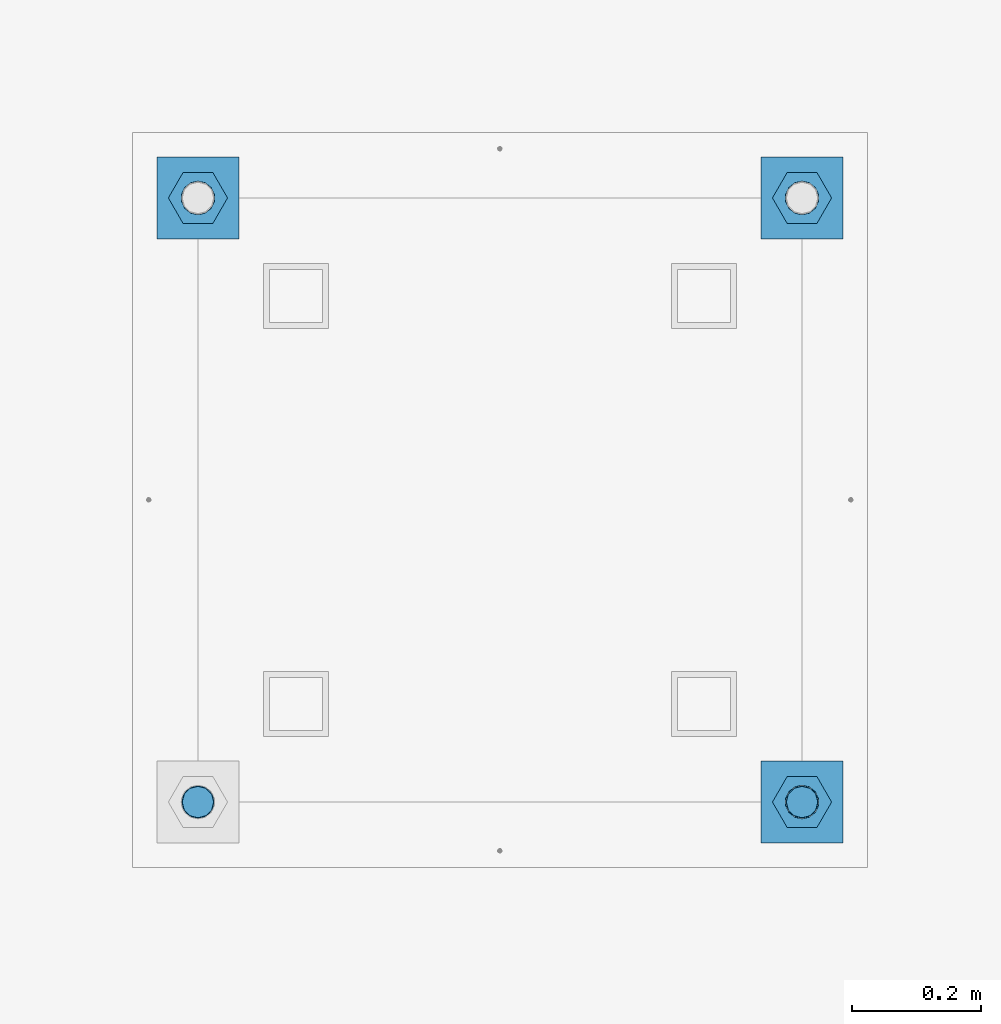
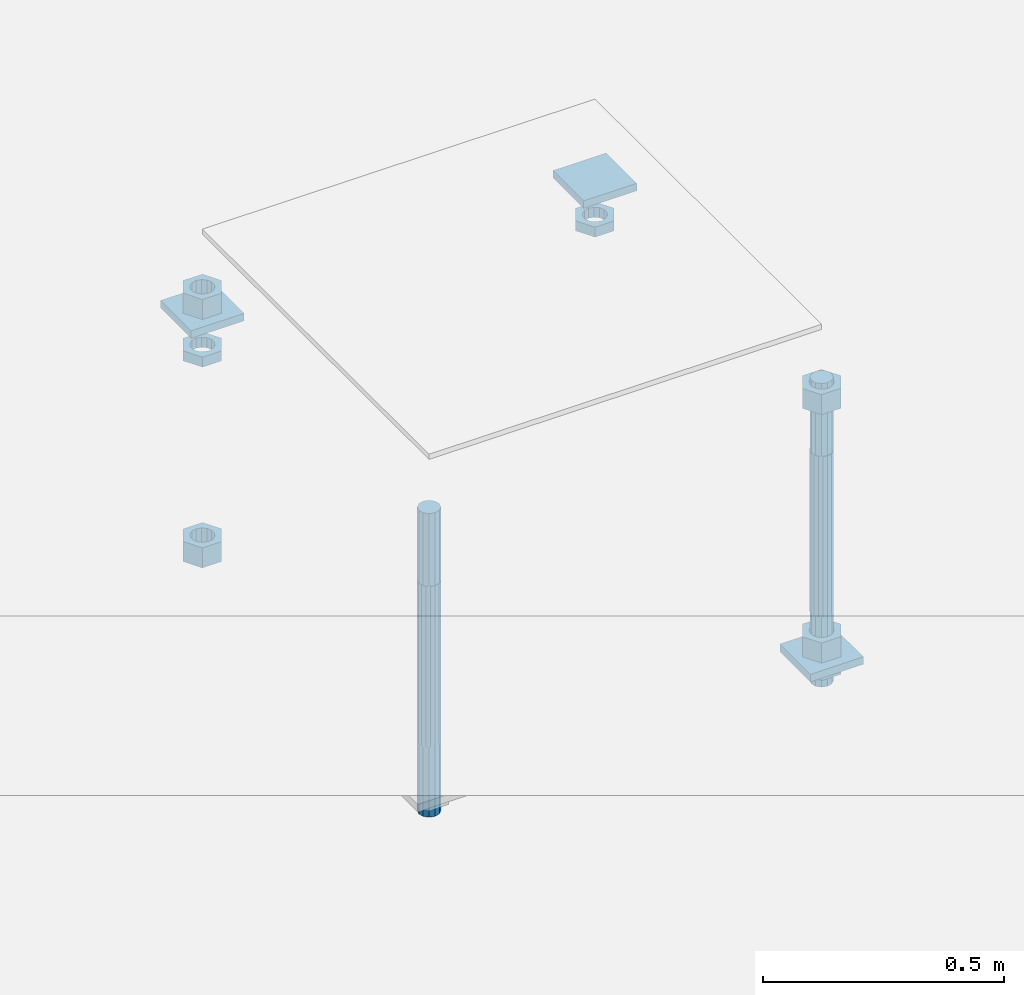
# One storey, part 2697 of 3843: 12 beams, 1 element without a shape of its own.
"""IFC2X3 building model written with IfcOpenShell, lengths in millimetres."""

import ifcopenshell
import ifcopenshell.guid

model = None  # the IFC model being written
_history = None  # IfcOwnerHistory: only IFC2X3 demands one
_inside = {}  # id of a spatial element -> (the spatial element, [elements in it])
_under = {}  # id of a project, library or spatial element -> (it, [spatial elements below it])
_declared = {}  # id of a project -> (the project, [libraries it declares])
_typed = {}  # id of a type object -> (the type object, [elements of that type])
_made_of = {}  # id of a material, layer set ... -> (it, [elements and type objects made of it])


def new_model(schema):
    """Start an empty IFC model of exactly this schema.

    Asked for "IFC4X3", IfcOpenShell would pick the latest addendum, in which some entities
    have other attributes; the version numbers below select the first issue.
    IFC2X3 requires an IfcOwnerHistory on every rooted entity: one is made here for all.
    """
    global model, _history
    if schema == "IFC4X3":
        model = ifcopenshell.file(schema_version=(4, 3, 0, 0))
    else:
        model = ifcopenshell.file(schema=schema)
    _inside.clear()
    _under.clear()
    _declared.clear()
    _typed.clear()
    _made_of.clear()
    _history = None
    if model.schema == "IFC2X3":
        org = make("IfcOrganization", Name="unknown")
        user = make(
            "IfcPersonAndOrganization",
            ThePerson=make("IfcPerson", FamilyName="unknown"),
            TheOrganization=org,
        )
        app = make(
            "IfcApplication",
            ApplicationDeveloper=org,
            Version="unknown",
            ApplicationFullName="unknown",
            ApplicationIdentifier="unknown",
        )
        _history = make(
            "IfcOwnerHistory",
            OwningUser=user,
            OwningApplication=app,
            ChangeAction="ADDED",
            CreationDate=0,
        )
    return model


def make(cls, **values):
    """One entity of the class cls with the attributes given. An attribute that is None is left unset."""
    return model.create_entity(
        cls, **{name: value for name, value in values.items() if value is not None}
    )


def rooted(cls, **values):
    """An entity with a GlobalId (a new one), such as an element, a storey or a relation."""
    return make(cls, GlobalId=ifcopenshell.guid.new(), OwnerHistory=_history, **values)


def si_unit(unit_type, name, prefix=None):
    """IfcSIUnit, for example si_unit("LENGTHUNIT", "METRE", prefix="MILLI")."""
    return make("IfcSIUnit", UnitType=unit_type, Prefix=prefix, Name=name)


def assignment(units):
    """IfcUnitAssignment: the units of a project."""
    return None if units is None else make("IfcUnitAssignment", Units=units)


def point(xyz):
    """IfcCartesianPoint."""
    return None if xyz is None else make("IfcCartesianPoint", Coordinates=xyz)


def direction(xyz):
    """IfcDirection."""
    return None if xyz is None else make("IfcDirection", DirectionRatios=xyz)


def frame(location, z_axis=None, x_axis=None):
    """IfcAxis2Placement3D, a coordinate frame: its origin and axes. An axis left out is left unset."""
    return make(
        "IfcAxis2Placement3D",
        Location=point(location),
        Axis=direction(z_axis),
        RefDirection=direction(x_axis),
    )


def origin_with_axes():
    """The frame at (0, 0, 0) with the z axis (0, 0, 1) and the x axis (1, 0, 0) written out."""
    return frame((0.0, 0.0, 0.0), z_axis=(0.0, 0.0, 1.0), x_axis=(1.0, 0.0, 0.0))


def place(relative_to, where):
    """IfcLocalPlacement: puts the frame where relative to a parent placement (None: the world)."""
    return make(
        "IfcLocalPlacement", PlacementRelTo=relative_to, RelativePlacement=where
    )


def context(
    kind, dimensions, precision=None, world=None, true_north=None, identifier=None
):
    """IfcGeometricRepresentationContext, for example the 3D "Model" context."""
    return make(
        "IfcGeometricRepresentationContext",
        ContextIdentifier=identifier,
        ContextType=kind,
        CoordinateSpaceDimension=dimensions,
        Precision=precision,
        WorldCoordinateSystem=world,
        TrueNorth=true_north,
    )


def subcontext(parent, identifier, kind, view, scale=None):
    """IfcGeometricRepresentationSubContext, for example "Body" below "Model"."""
    return make(
        "IfcGeometricRepresentationSubContext",
        ContextIdentifier=identifier,
        ContextType=kind,
        ParentContext=parent,
        TargetScale=scale,
        TargetView=view,
    )


def project(units=None, contexts=None):
    """IfcProject with its units and contexts."""
    return rooted(
        "IfcProject",
        Name="project",
        RepresentationContexts=contexts,
        UnitsInContext=assignment(units),
    )


def spatial(cls, under=None, at=None, **own):
    """A site, building, storey or space (cls), placed at a placement, below another one or the project."""
    s = rooted(cls, ObjectPlacement=at, **own)
    if under is not None:
        _under.setdefault(under.id(), (under, []))[1].append(s)
    return s


def faces_of(points, faces, orient=None, outer=None):
    """IfcFace entities. A face is a list of loops; a loop is a list of indices into points, from 0.

    orient and outer hold one flag for each loop. By default every Orientation is true, the
    first loop of a face is its IfcFaceOuterBound and the others are IfcFaceBound.
    """
    made = []
    for i, loops in enumerate(faces):
        bounds = []
        for j, loop in enumerate(loops):
            is_outer = j == 0 if outer is None else outer[i][j]
            bounds.append(
                make(
                    "IfcFaceOuterBound" if is_outer else "IfcFaceBound",
                    Bound=make("IfcPolyLoop", Polygon=[points[k] for k in loop]),
                    Orientation=True if orient is None else orient[i][j],
                )
            )
        made.append(make("IfcFace", Bounds=bounds))
    return made


def faceted_brep(points, faces, orient=None, outer=None, voids=None):
    """IfcFacetedBrep: a solid bounded by flat faces; with voids (closed shells), ...WithVoids."""
    shared = [point(p) for p in points]
    hull = make("IfcClosedShell", CfsFaces=faces_of(shared, faces, orient, outer))
    if voids is None:
        return make("IfcFacetedBrep", Outer=hull)
    return make(
        "IfcFacetedBrepWithVoids",
        Outer=hull,
        Voids=[
            make(cls, CfsFaces=faces_of(shared, fs, o, b)) for cls, fs, o, b in voids
        ],
    )


def shape(context_of_items, identifier, shape_type, items):
    """IfcShapeRepresentation: the items that make up one representation, for example the "Body"."""
    return make(
        "IfcShapeRepresentation",
        ContextOfItems=context_of_items,
        RepresentationIdentifier=identifier,
        RepresentationType=shape_type,
        Items=items,
    )


def material(Name=None, Category=None):
    """IfcMaterial."""
    return make("IfcMaterial", Name=Name, Category=Category)


def made_of(thing, what):
    """Note that an element or type object is made of a material, layer set ...; save() writes the relation."""
    if what is not None:
        _made_of.setdefault(what.id(), (what, []))[1].append(thing)
    return thing


def type_object(cls, material=None, **own):
    """A type object (cls), such as IfcWallType, which elements share."""
    return made_of(rooted(cls, **own), material)


def element(
    cls,
    number,
    at=None,
    inside=None,
    cuts=None,
    type_object=None,
    material=None,
    context=None,
    identifier="Body",
    shape_type=None,
    held_by="IfcProductDefinitionShape",
    body=None,
    shapes=None,
    **own,
):
    """One element of the class cls, such as IfcWall. Its Tag is "e" and its number.

    at: its placement. inside: the storey or other place that contains it. cuts: it is an
    opening in that element (IfcRelVoidsElement). A single representation is given by context,
    identifier, shape_type and body (its items); several are given by shapes. held_by: the class
    of the entity that holds the representations. save() writes the other relations.
    """
    e = rooted(cls, Tag="e%d" % number, ObjectPlacement=at, **own)
    if body is not None:
        shapes = [shape(context, identifier, shape_type, body)]
    if shapes is not None:
        e.Representation = make(held_by, Representations=shapes)
    if inside is not None:
        _inside.setdefault(inside.id(), (inside, []))[1].append(e)
    if cuts is not None:
        rooted(
            "IfcRelVoidsElement", RelatingBuildingElement=cuts, RelatedOpeningElement=e
        )
    if type_object is not None:
        _typed.setdefault(type_object.id(), (type_object, []))[1].append(e)
    return made_of(e, material)


def aggregate(whole, parts):
    """IfcRelAggregates: a whole, such as a stair, and the parts it consists of."""
    return rooted("IfcRelAggregates", RelatingObject=whole, RelatedObjects=parts)


def save(model, path):
    """Write the relations noted so far, then the file.

    IfcRelAggregates (storeys below a building ...), IfcRelContainedInSpatialStructure (elements
    in a storey), IfcRelDefinesByType, IfcRelAssociatesMaterial and IfcRelDeclares: one each for
    every whole, place, type object, material and project.
    """
    for whole, parts in _under.values():
        aggregate(whole, parts)
    for where, things in _inside.values():
        rooted(
            "IfcRelContainedInSpatialStructure",
            RelatedElements=things,
            RelatingStructure=where,
        )
    for kind, things in _typed.values():
        rooted("IfcRelDefinesByType", RelatedObjects=things, RelatingType=kind)
    for what, things in _made_of.values():
        rooted("IfcRelAssociatesMaterial", RelatedObjects=things, RelatingMaterial=what)
    for by, libraries in _declared.values():
        rooted("IfcRelDeclares", RelatingContext=by, RelatedDefinitions=libraries)
    model.write(path)


model = new_model("IFC2X3")

# Units and contexts
model_context = context("Model", 3, precision=1e-05, world=origin_with_axes())
body_context = subcontext(model_context, "Body", "Model", "MODEL_VIEW")
ifc_project = project(units=[si_unit("LENGTHUNIT", "METRE", prefix="MILLI"), si_unit("AREAUNIT", "SQUARE_METRE"), si_unit("VOLUMEUNIT", "CUBIC_METRE"), si_unit("MASSUNIT", "GRAM", prefix="KILO"), si_unit("TIMEUNIT", "SECOND"), si_unit("PLANEANGLEUNIT", "RADIAN"), si_unit("SOLIDANGLEUNIT", "STERADIAN"), si_unit("THERMODYNAMICTEMPERATUREUNIT", "DEGREE_CELSIUS"), si_unit("LUMINOUSINTENSITYUNIT", "LUMEN")], contexts=[model_context])

# Site, building, storey
site_placement = place(None, origin_with_axes())
site = spatial("IfcSite", under=ifc_project, at=site_placement, CompositionType="ELEMENT")
building_placement = place(site_placement, origin_with_axes())
building = spatial("IfcBuilding", under=site, at=building_placement, Name="Undefined", CompositionType="ELEMENT")
storey_placement = place(building_placement, origin_with_axes())
storey = spatial("IfcBuildingStorey", under=building, at=storey_placement, Name="Undefined", CompositionType="ELEMENT", Elevation=0.0)

# Assembly, beams
assembly_placement = place(storey_placement, origin_with_axes())
assembly = element("IfcElementAssembly", 1, at=assembly_placement, inside=storey, Name="TEMPLATE", AssemblyPlace="NOTDEFINED", PredefinedType="RIGID_FRAME")
ifc_material_1 = material(Name="STEEL/A36")
beam_type_1 = type_object("IfcBeamType", PredefinedType="NOTDEFINED")
beam_1_placement = place(assembly_placement, frame((108483.4, 38963.6000015259, 29873.575), z_axis=(1.0, 0.0, 0.0), x_axis=(0.0, 1.0, 0.0)))
beam_1 = element("IfcBeam", 2, at=beam_1_placement, type_object=beam_type_1, material=ifc_material_1, Name="WASHER_PLATE", context=body_context, shape_type="Brep", body=[
    faceted_brep([(0.0, 9.52500000000146, -63.5), (0.0, 9.52500000000146, 63.5), (127.0, 9.52500000000146, 63.5), (127.0, 9.52500000000146, -63.5), (0.0, -9.52500000000146, 63.5), (127.0, -9.52500000000146, 63.5), (0.0, -9.52500000000146, -63.5), (127.0, -9.52500000000146, -63.5)], [[[0, 1, 2, 3]], [[1, 4, 5, 2]], [[4, 6, 7, 5]], [[6, 0, 3, 7]], [[5, 7, 3, 2]], [[6, 4, 1, 0]]]),
])
beam_2_placement = place(assembly_placement, frame((109423.2, 38963.6000015259, 29873.575), z_axis=(1.0, 0.0, 0.0), x_axis=(0.0, 1.0, 0.0)))
beam_2 = element("IfcBeam", 3, at=beam_2_placement, type_object=beam_type_1, material=ifc_material_1, Name="WASHER_PLATE", context=body_context, shape_type="Brep", body=[
    faceted_brep([(0.0, 9.52500000000146, -63.5), (0.0, 9.52500000000146, 63.5), (127.0, 9.52500000000146, 63.5), (127.0, 9.52500000000146, -63.5), (0.0, -9.52500000000146, 63.5), (127.0, -9.52500000000146, 63.5), (0.0, -9.52500000000146, -63.5), (127.0, -9.52500000000146, -63.5)], [[[0, 1, 2, 3]], [[1, 4, 5, 2]], [[4, 6, 7, 5]], [[6, 0, 3, 7]], [[5, 7, 3, 2]], [[6, 4, 1, 0]]]),
])
beam_3_placement = place(assembly_placement, frame((109423.2, 38023.8000015259, 29244.925), z_axis=(1.0, 0.0, 0.0), x_axis=(0.0, 1.0, 0.0)))
beam_3 = element("IfcBeam", 4, at=beam_3_placement, type_object=beam_type_1, material=ifc_material_1, Name="WASHER_PLATE", context=body_context, shape_type="Brep", body=[
    faceted_brep([(0.0, 9.52500000000146, -63.5), (0.0, 9.52500000000146, 63.5), (127.0, 9.52500000000146, 63.5), (127.0, 9.52500000000146, -63.5), (0.0, -9.52500000000146, 63.5), (127.0, -9.52500000000146, 63.5), (0.0, -9.52500000000146, -63.5), (127.0, -9.52500000000146, -63.5)], [[[0, 1, 2, 3]], [[1, 4, 5, 2]], [[4, 6, 7, 5]], [[6, 0, 3, 7]], [[5, 7, 3, 2]], [[6, 4, 1, 0]]]),
])
beam_type_2 = type_object("IfcBeamType", Name="2_HALF_NUT", PredefinedType="NOTDEFINED")
beam_4_placement = place(assembly_placement, frame((108483.4, 39027.1000015259, 29787.85), z_axis=(0.0, -1.0, 0.0), x_axis=(0.0, 0.0, -1.0)))
beam_4 = element("IfcBeam", 5, at=beam_4_placement, type_object=beam_type_2, material=ifc_material_1, Name="NUT", ObjectType="2_HALF_NUT", context=body_context, shape_type="Brep", body=[
    faceted_brep([(0.0, -46.0369987487793, 0.0), (0.0, -23.0184993743896, -39.869213104248), (25.4000000000015, -23.0184993743896, -39.869213104248), (25.4000000000015, -46.0369987487793, 0.0), (0.0, 23.0184993743896, -39.869213104248), (25.4000000000015, 23.0184993743896, -39.869213104248), (0.0, 46.0369987487793, 0.0), (25.4000000000015, 46.0369987487793, 0.0), (0.0, 23.0184993743896, 39.869213104248), (25.4000000000015, 23.0184993743896, 39.869213104248), (0.0, -23.0184993743896, 39.869213104248), (25.4000000000015, -23.0184993743896, 39.869213104248), (0.0, 0.0, 26.1940002441406), (0.0, 11.3650617044477, 23.5999013092805), (25.4000000000015, 11.3650617044477, 23.5999013092805), (25.4000000000015, 0.0, 26.1940002441406), (0.0, 20.4791109456419, 16.3316083006721), (25.4000000000015, 20.4791109456419, 16.3316083006721), (0.0, 25.5370200498292, 5.82867859874386), (25.4000000000015, 25.5370200498292, 5.82867859874386), (0.0, 25.5370200498292, -5.82867859874386), (25.4000000000015, 25.5370200498292, -5.82867859874386), (0.0, 20.4791109456419, -16.3316083006721), (25.4000000000015, 20.4791109456419, -16.3316083006721), (0.0, 11.3650617044477, -23.5999013092805), (25.4000000000015, 11.3650617044477, -23.5999013092805), (0.0, 0.0, -26.1940002441406), (25.4000000000015, 0.0, -26.1940002441406), (0.0, -11.3650617044477, -23.5999013092805), (25.4000000000015, -11.3650617044477, -23.5999013092805), (0.0, -20.4791109456419, -16.3316083006721), (25.4000000000015, -20.4791109456419, -16.3316083006721), (0.0, -25.5370200498292, -5.82867859874386), (25.4000000000015, -25.5370200498292, -5.82867859874386), (0.0, -25.5370200498292, 5.82867859874386), (25.4000000000015, -25.5370200498292, 5.82867859874386), (0.0, -20.4791109456419, 16.3316083006721), (25.4000000000015, -20.4791109456419, 16.3316083006721), (0.0, -11.3650617044477, 23.5999013092805), (25.4000000000015, -11.3650617044477, 23.5999013092805)], [[[0, 1, 2, 3]], [[1, 4, 5, 2]], [[4, 6, 7, 5]], [[6, 8, 9, 7]], [[8, 10, 11, 9]], [[10, 0, 3, 11]], [[12, 13, 14, 15]], [[13, 16, 17, 14]], [[16, 18, 19, 17]], [[18, 20, 21, 19]], [[20, 22, 23, 21]], [[22, 24, 25, 23]], [[24, 26, 27, 25]], [[26, 28, 29, 27]], [[28, 30, 31, 29]], [[30, 32, 33, 31]], [[32, 34, 35, 33]], [[34, 36, 37, 35]], [[36, 38, 39, 37]], [[38, 12, 15, 39]], [[5, 7, 9, 11, 3, 2], [17, 19, 21, 23, 25, 27, 29, 31, 33, 35, 37, 39, 15, 14]], [[10, 8, 6, 4, 1, 0], [38, 36, 34, 32, 30, 28, 26, 24, 22, 20, 18, 16, 13, 12]]]),
])
beam_5_placement = place(assembly_placement, frame((109423.2, 39027.1000015259, 29787.85), z_axis=(0.0, 1.0, 0.0), x_axis=(0.0, 0.0, -1.0)))
beam_5 = element("IfcBeam", 6, at=beam_5_placement, type_object=beam_type_2, material=ifc_material_1, Name="NUT", ObjectType="2_HALF_NUT", context=body_context, shape_type="Brep", body=[
    faceted_brep([(0.0, -46.0369987487793, 0.0), (0.0, -23.0184993743896, -39.869213104248), (25.4000000000015, -23.0184993743896, -39.869213104248), (25.4000000000015, -46.0369987487793, 0.0), (0.0, 23.0184993743896, -39.869213104248), (25.4000000000015, 23.0184993743896, -39.869213104248), (0.0, 46.0369987487793, 0.0), (25.4000000000015, 46.0369987487793, 0.0), (0.0, 23.0184993743896, 39.869213104248), (25.4000000000015, 23.0184993743896, 39.869213104248), (0.0, -23.0184993743896, 39.869213104248), (25.4000000000015, -23.0184993743896, 39.869213104248), (0.0, 0.0, 26.1940002441406), (0.0, 11.3650617044477, 23.5999013092805), (25.4000000000015, 11.3650617044477, 23.5999013092805), (25.4000000000015, 0.0, 26.1940002441406), (0.0, 20.4791109456419, 16.3316083006721), (25.4000000000015, 20.4791109456419, 16.3316083006721), (0.0, 25.5370200498292, 5.82867859874386), (25.4000000000015, 25.5370200498292, 5.82867859874386), (0.0, 25.5370200498292, -5.82867859874386), (25.4000000000015, 25.5370200498292, -5.82867859874386), (0.0, 20.4791109456419, -16.3316083006721), (25.4000000000015, 20.4791109456419, -16.3316083006721), (0.0, 11.3650617044477, -23.5999013092805), (25.4000000000015, 11.3650617044477, -23.5999013092805), (0.0, 0.0, -26.1940002441406), (25.4000000000015, 0.0, -26.1940002441406), (0.0, -11.3650617044477, -23.5999013092805), (25.4000000000015, -11.3650617044477, -23.5999013092805), (0.0, -20.4791109456419, -16.3316083006721), (25.4000000000015, -20.4791109456419, -16.3316083006721), (0.0, -25.5370200498292, -5.82867859874386), (25.4000000000015, -25.5370200498292, -5.82867859874386), (0.0, -25.5370200498292, 5.82867859874386), (25.4000000000015, -25.5370200498292, 5.82867859874386), (0.0, -20.4791109456419, 16.3316083006721), (25.4000000000015, -20.4791109456419, 16.3316083006721), (0.0, -11.3650617044477, 23.5999013092805), (25.4000000000015, -11.3650617044477, 23.5999013092805)], [[[0, 1, 2, 3]], [[1, 4, 5, 2]], [[4, 6, 7, 5]], [[6, 8, 9, 7]], [[8, 10, 11, 9]], [[10, 0, 3, 11]], [[12, 13, 14, 15]], [[13, 16, 17, 14]], [[16, 18, 19, 17]], [[18, 20, 21, 19]], [[20, 22, 23, 21]], [[22, 24, 25, 23]], [[24, 26, 27, 25]], [[26, 28, 29, 27]], [[28, 30, 31, 29]], [[30, 32, 33, 31]], [[32, 34, 35, 33]], [[34, 36, 37, 35]], [[36, 38, 39, 37]], [[38, 12, 15, 39]], [[5, 7, 9, 11, 3, 2], [17, 19, 21, 23, 25, 27, 29, 31, 33, 35, 37, 39, 15, 14]], [[10, 8, 6, 4, 1, 0], [38, 36, 34, 32, 30, 28, 26, 24, 22, 20, 18, 16, 13, 12]]]),
])
beam_6_placement = place(assembly_placement, frame((109423.2, 38087.3000015259, 29235.4), z_axis=(0.0, 1.0, 0.0), x_axis=(0.0, 0.0, -1.0)))
beam_6 = element("IfcBeam", 7, at=beam_6_placement, type_object=beam_type_2, material=ifc_material_1, Name="NUT", ObjectType="2_HALF_NUT", context=body_context, shape_type="Brep", body=[
    faceted_brep([(0.0, -46.0369987487793, 0.0), (0.0, -23.0184993743896, -39.869213104248), (25.4000000000015, -23.0184993743896, -39.869213104248), (25.4000000000015, -46.0369987487793, 0.0), (0.0, 23.0184993743896, -39.869213104248), (25.4000000000015, 23.0184993743896, -39.869213104248), (0.0, 46.0369987487793, 0.0), (25.4000000000015, 46.0369987487793, 0.0), (0.0, 23.0184993743896, 39.869213104248), (25.4000000000015, 23.0184993743896, 39.869213104248), (0.0, -23.0184993743896, 39.869213104248), (25.4000000000015, -23.0184993743896, 39.869213104248), (0.0, 0.0, 26.1940002441406), (0.0, 11.3650617044477, 23.5999013092805), (25.4000000000015, 11.3650617044477, 23.5999013092805), (25.4000000000015, 0.0, 26.1940002441406), (0.0, 20.4791109456419, 16.3316083006721), (25.4000000000015, 20.4791109456419, 16.3316083006721), (0.0, 25.5370200498292, 5.82867859874386), (25.4000000000015, 25.5370200498292, 5.82867859874386), (0.0, 25.5370200498292, -5.82867859874386), (25.4000000000015, 25.5370200498292, -5.82867859874386), (0.0, 20.4791109456419, -16.3316083006721), (25.4000000000015, 20.4791109456419, -16.3316083006721), (0.0, 11.3650617044477, -23.5999013092805), (25.4000000000015, 11.3650617044477, -23.5999013092805), (0.0, 0.0, -26.1940002441406), (25.4000000000015, 0.0, -26.1940002441406), (0.0, -11.3650617044477, -23.5999013092805), (25.4000000000015, -11.3650617044477, -23.5999013092805), (0.0, -20.4791109456419, -16.3316083006721), (25.4000000000015, -20.4791109456419, -16.3316083006721), (0.0, -25.5370200498292, -5.82867859874386), (25.4000000000015, -25.5370200498292, -5.82867859874386), (0.0, -25.5370200498292, 5.82867859874386), (25.4000000000015, -25.5370200498292, 5.82867859874386), (0.0, -20.4791109456419, 16.3316083006721), (25.4000000000015, -20.4791109456419, 16.3316083006721), (0.0, -11.3650617044477, 23.5999013092805), (25.4000000000015, -11.3650617044477, 23.5999013092805)], [[[0, 1, 2, 3]], [[1, 4, 5, 2]], [[4, 6, 7, 5]], [[6, 8, 9, 7]], [[8, 10, 11, 9]], [[10, 0, 3, 11]], [[12, 13, 14, 15]], [[13, 16, 17, 14]], [[16, 18, 19, 17]], [[18, 20, 21, 19]], [[20, 22, 23, 21]], [[22, 24, 25, 23]], [[24, 26, 27, 25]], [[26, 28, 29, 27]], [[28, 30, 31, 29]], [[30, 32, 33, 31]], [[32, 34, 35, 33]], [[34, 36, 37, 35]], [[36, 38, 39, 37]], [[38, 12, 15, 39]], [[5, 7, 9, 11, 3, 2], [17, 19, 21, 23, 25, 27, 29, 31, 33, 35, 37, 39, 15, 14]], [[10, 8, 6, 4, 1, 0], [38, 36, 34, 32, 30, 28, 26, 24, 22, 20, 18, 16, 13, 12]]]),
])
beam_type_3 = type_object("IfcBeamType", Name="2_HEAVY_HEX_NUT", PredefinedType="NOTDEFINED")
beam_7_placement = place(assembly_placement, frame((109423.2, 38087.3000015259, 29933.9), z_axis=(0.0, 1.0, 0.0), x_axis=(0.0, 0.0, -1.0)))
beam_7 = element("IfcBeam", 8, at=beam_7_placement, type_object=beam_type_3, material=ifc_material_1, Name="NUT", ObjectType="2_HEAVY_HEX_NUT", context=body_context, shape_type="Brep", body=[
    faceted_brep([(0.0, -46.0369987487793, 0.0), (0.0, -23.0184993743896, -39.869213104248), (50.7999999999993, -23.0184993743896, -39.869213104248), (50.7999999999993, -46.0369987487793, 0.0), (0.0, 23.0184993743896, -39.869213104248), (50.7999999999993, 23.0184993743896, -39.869213104248), (0.0, 46.0369987487793, 0.0), (50.7999999999993, 46.0369987487793, 0.0), (0.0, 23.0184993743896, 39.869213104248), (50.7999999999993, 23.0184993743896, 39.869213104248), (0.0, -23.0184993743896, 39.869213104248), (50.7999999999993, -23.0184993743896, 39.869213104248), (0.0, 0.0, 26.1940002441406), (0.0, 11.3650617044477, 23.5999013092805), (50.7999999999993, 11.3650617044477, 23.5999013092805), (50.7999999999993, 0.0, 26.1940002441406), (0.0, 20.4791109456419, 16.3316083006721), (50.7999999999993, 20.4791109456419, 16.3316083006721), (0.0, 25.5370200498292, 5.82867859874386), (50.7999999999993, 25.5370200498292, 5.82867859874386), (0.0, 25.5370200498292, -5.82867859874386), (50.7999999999993, 25.5370200498292, -5.82867859874386), (0.0, 20.4791109456419, -16.3316083006721), (50.7999999999993, 20.4791109456419, -16.3316083006721), (0.0, 11.3650617044477, -23.5999013092805), (50.7999999999993, 11.3650617044477, -23.5999013092805), (0.0, 0.0, -26.1940002441406), (50.7999999999993, 0.0, -26.1940002441406), (0.0, -11.3650617044477, -23.5999013092805), (50.7999999999993, -11.3650617044477, -23.5999013092805), (0.0, -20.4791109456419, -16.3316083006721), (50.7999999999993, -20.4791109456419, -16.3316083006721), (0.0, -25.5370200498292, -5.82867859874386), (50.7999999999993, -25.5370200498292, -5.82867859874386), (0.0, -25.5370200498292, 5.82867859874386), (50.7999999999993, -25.5370200498292, 5.82867859874386), (0.0, -20.4791109456419, 16.3316083006721), (50.7999999999993, -20.4791109456419, 16.3316083006721), (0.0, -11.3650617044477, 23.5999013092805), (50.7999999999993, -11.3650617044477, 23.5999013092805)], [[[0, 1, 2, 3]], [[1, 4, 5, 2]], [[4, 6, 7, 5]], [[6, 8, 9, 7]], [[8, 10, 11, 9]], [[10, 0, 3, 11]], [[12, 13, 14, 15]], [[13, 16, 17, 14]], [[16, 18, 19, 17]], [[18, 20, 21, 19]], [[20, 22, 23, 21]], [[22, 24, 25, 23]], [[24, 26, 27, 25]], [[26, 28, 29, 27]], [[28, 30, 31, 29]], [[30, 32, 33, 31]], [[32, 34, 35, 33]], [[34, 36, 37, 35]], [[36, 38, 39, 37]], [[38, 12, 15, 39]], [[5, 7, 9, 11, 3, 2], [17, 19, 21, 23, 25, 27, 29, 31, 33, 35, 37, 39, 15, 14]], [[10, 8, 6, 4, 1, 0], [38, 36, 34, 32, 30, 28, 26, 24, 22, 20, 18, 16, 13, 12]]]),
])
beam_8_placement = place(assembly_placement, frame((109423.2, 38087.3000015259, 29305.25), z_axis=(0.0, 1.0, 0.0), x_axis=(0.0, 0.0, -1.0)))
beam_8 = element("IfcBeam", 9, at=beam_8_placement, type_object=beam_type_3, material=ifc_material_1, Name="NUT", ObjectType="2_HEAVY_HEX_NUT", context=body_context, shape_type="Brep", body=[
    faceted_brep([(0.0, -46.0369987487793, 0.0), (0.0, -23.0184993743896, -39.869213104248), (50.7999999999993, -23.0184993743896, -39.869213104248), (50.7999999999993, -46.0369987487793, 0.0), (0.0, 23.0184993743896, -39.869213104248), (50.7999999999993, 23.0184993743896, -39.869213104248), (0.0, 46.0369987487793, 0.0), (50.7999999999993, 46.0369987487793, 0.0), (0.0, 23.0184993743896, 39.869213104248), (50.7999999999993, 23.0184993743896, 39.869213104248), (0.0, -23.0184993743896, 39.869213104248), (50.7999999999993, -23.0184993743896, 39.869213104248), (0.0, 0.0, 26.1940002441406), (0.0, 11.3650617044477, 23.5999013092805), (50.7999999999993, 11.3650617044477, 23.5999013092805), (50.7999999999993, 0.0, 26.1940002441406), (0.0, 20.4791109456419, 16.3316083006721), (50.7999999999993, 20.4791109456419, 16.3316083006721), (0.0, 25.5370200498292, 5.82867859874386), (50.7999999999993, 25.5370200498292, 5.82867859874386), (0.0, 25.5370200498292, -5.82867859874386), (50.7999999999993, 25.5370200498292, -5.82867859874386), (0.0, 20.4791109456419, -16.3316083006721), (50.7999999999993, 20.4791109456419, -16.3316083006721), (0.0, 11.3650617044477, -23.5999013092805), (50.7999999999993, 11.3650617044477, -23.5999013092805), (0.0, 0.0, -26.1940002441406), (50.7999999999993, 0.0, -26.1940002441406), (0.0, -11.3650617044477, -23.5999013092805), (50.7999999999993, -11.3650617044477, -23.5999013092805), (0.0, -20.4791109456419, -16.3316083006721), (50.7999999999993, -20.4791109456419, -16.3316083006721), (0.0, -25.5370200498292, -5.82867859874386), (50.7999999999993, -25.5370200498292, -5.82867859874386), (0.0, -25.5370200498292, 5.82867859874386), (50.7999999999993, -25.5370200498292, 5.82867859874386), (0.0, -20.4791109456419, 16.3316083006721), (50.7999999999993, -20.4791109456419, 16.3316083006721), (0.0, -11.3650617044477, 23.5999013092805), (50.7999999999993, -11.3650617044477, 23.5999013092805)], [[[0, 1, 2, 3]], [[1, 4, 5, 2]], [[4, 6, 7, 5]], [[6, 8, 9, 7]], [[8, 10, 11, 9]], [[10, 0, 3, 11]], [[12, 13, 14, 15]], [[13, 16, 17, 14]], [[16, 18, 19, 17]], [[18, 20, 21, 19]], [[20, 22, 23, 21]], [[22, 24, 25, 23]], [[24, 26, 27, 25]], [[26, 28, 29, 27]], [[28, 30, 31, 29]], [[30, 32, 33, 31]], [[32, 34, 35, 33]], [[34, 36, 37, 35]], [[36, 38, 39, 37]], [[38, 12, 15, 39]], [[5, 7, 9, 11, 3, 2], [17, 19, 21, 23, 25, 27, 29, 31, 33, 35, 37, 39, 15, 14]], [[10, 8, 6, 4, 1, 0], [38, 36, 34, 32, 30, 28, 26, 24, 22, 20, 18, 16, 13, 12]]]),
])
beam_9_placement = place(assembly_placement, frame((108483.4, 39027.1000015259, 29933.9), z_axis=(0.0, -1.0, 0.0), x_axis=(0.0, 0.0, -1.0)))
beam_9 = element("IfcBeam", 10, at=beam_9_placement, type_object=beam_type_3, material=ifc_material_1, Name="NUT", ObjectType="2_HEAVY_HEX_NUT", context=body_context, shape_type="Brep", body=[
    faceted_brep([(0.0, -46.0369987487793, 0.0), (0.0, -23.0184993743896, -39.869213104248), (50.7999999999993, -23.0184993743896, -39.869213104248), (50.7999999999993, -46.0369987487793, 0.0), (0.0, 23.0184993743896, -39.869213104248), (50.7999999999993, 23.0184993743896, -39.869213104248), (0.0, 46.0369987487793, 0.0), (50.7999999999993, 46.0369987487793, 0.0), (0.0, 23.0184993743896, 39.869213104248), (50.7999999999993, 23.0184993743896, 39.869213104248), (0.0, -23.0184993743896, 39.869213104248), (50.7999999999993, -23.0184993743896, 39.869213104248), (0.0, 0.0, 26.1940002441406), (0.0, 11.3650617044477, 23.5999013092805), (50.7999999999993, 11.3650617044477, 23.5999013092805), (50.7999999999993, 0.0, 26.1940002441406), (0.0, 20.4791109456419, 16.3316083006721), (50.7999999999993, 20.4791109456419, 16.3316083006721), (0.0, 25.5370200498292, 5.82867859874386), (50.7999999999993, 25.5370200498292, 5.82867859874386), (0.0, 25.5370200498292, -5.82867859874386), (50.7999999999993, 25.5370200498292, -5.82867859874386), (0.0, 20.4791109456419, -16.3316083006721), (50.7999999999993, 20.4791109456419, -16.3316083006721), (0.0, 11.3650617044477, -23.5999013092805), (50.7999999999993, 11.3650617044477, -23.5999013092805), (0.0, 0.0, -26.1940002441406), (50.7999999999993, 0.0, -26.1940002441406), (0.0, -11.3650617044477, -23.5999013092805), (50.7999999999993, -11.3650617044477, -23.5999013092805), (0.0, -20.4791109456419, -16.3316083006721), (50.7999999999993, -20.4791109456419, -16.3316083006721), (0.0, -25.5370200498292, -5.82867859874386), (50.7999999999993, -25.5370200498292, -5.82867859874386), (0.0, -25.5370200498292, 5.82867859874386), (50.7999999999993, -25.5370200498292, 5.82867859874386), (0.0, -20.4791109456419, 16.3316083006721), (50.7999999999993, -20.4791109456419, 16.3316083006721), (0.0, -11.3650617044477, 23.5999013092805), (50.7999999999993, -11.3650617044477, 23.5999013092805)], [[[0, 1, 2, 3]], [[1, 4, 5, 2]], [[4, 6, 7, 5]], [[6, 8, 9, 7]], [[8, 10, 11, 9]], [[10, 0, 3, 11]], [[12, 13, 14, 15]], [[13, 16, 17, 14]], [[16, 18, 19, 17]], [[18, 20, 21, 19]], [[20, 22, 23, 21]], [[22, 24, 25, 23]], [[24, 26, 27, 25]], [[26, 28, 29, 27]], [[28, 30, 31, 29]], [[30, 32, 33, 31]], [[32, 34, 35, 33]], [[34, 36, 37, 35]], [[36, 38, 39, 37]], [[38, 12, 15, 39]], [[5, 7, 9, 11, 3, 2], [17, 19, 21, 23, 25, 27, 29, 31, 33, 35, 37, 39, 15, 14]], [[10, 8, 6, 4, 1, 0], [38, 36, 34, 32, 30, 28, 26, 24, 22, 20, 18, 16, 13, 12]]]),
])
beam_10_placement = place(assembly_placement, frame((108483.4, 39027.1000015259, 29305.25), z_axis=(0.0, -1.0, 0.0), x_axis=(0.0, 0.0, -1.0)))
beam_10 = element("IfcBeam", 11, at=beam_10_placement, type_object=beam_type_3, material=ifc_material_1, Name="NUT", ObjectType="2_HEAVY_HEX_NUT", context=body_context, shape_type="Brep", body=[
    faceted_brep([(0.0, -46.0369987487793, 0.0), (0.0, -23.0184993743896, -39.869213104248), (50.7999999999993, -23.0184993743896, -39.869213104248), (50.7999999999993, -46.0369987487793, 0.0), (0.0, 23.0184993743896, -39.869213104248), (50.7999999999993, 23.0184993743896, -39.869213104248), (0.0, 46.0369987487793, 0.0), (50.7999999999993, 46.0369987487793, 0.0), (0.0, 23.0184993743896, 39.869213104248), (50.7999999999993, 23.0184993743896, 39.869213104248), (0.0, -23.0184993743896, 39.869213104248), (50.7999999999993, -23.0184993743896, 39.869213104248), (0.0, 0.0, 26.1940002441406), (0.0, 11.3650617044477, 23.5999013092805), (50.7999999999993, 11.3650617044477, 23.5999013092805), (50.7999999999993, 0.0, 26.1940002441406), (0.0, 20.4791109456419, 16.3316083006721), (50.7999999999993, 20.4791109456419, 16.3316083006721), (0.0, 25.5370200498292, 5.82867859874386), (50.7999999999993, 25.5370200498292, 5.82867859874386), (0.0, 25.5370200498292, -5.82867859874386), (50.7999999999993, 25.5370200498292, -5.82867859874386), (0.0, 20.4791109456419, -16.3316083006721), (50.7999999999993, 20.4791109456419, -16.3316083006721), (0.0, 11.3650617044477, -23.5999013092805), (50.7999999999993, 11.3650617044477, -23.5999013092805), (0.0, 0.0, -26.1940002441406), (50.7999999999993, 0.0, -26.1940002441406), (0.0, -11.3650617044477, -23.5999013092805), (50.7999999999993, -11.3650617044477, -23.5999013092805), (0.0, -20.4791109456419, -16.3316083006721), (50.7999999999993, -20.4791109456419, -16.3316083006721), (0.0, -25.5370200498292, -5.82867859874386), (50.7999999999993, -25.5370200498292, -5.82867859874386), (0.0, -25.5370200498292, 5.82867859874386), (50.7999999999993, -25.5370200498292, 5.82867859874386), (0.0, -20.4791109456419, 16.3316083006721), (50.7999999999993, -20.4791109456419, 16.3316083006721), (0.0, -11.3650617044477, 23.5999013092805), (50.7999999999993, -11.3650617044477, 23.5999013092805)], [[[0, 1, 2, 3]], [[1, 4, 5, 2]], [[4, 6, 7, 5]], [[6, 8, 9, 7]], [[8, 10, 11, 9]], [[10, 0, 3, 11]], [[12, 13, 14, 15]], [[13, 16, 17, 14]], [[16, 18, 19, 17]], [[18, 20, 21, 19]], [[20, 22, 23, 21]], [[22, 24, 25, 23]], [[24, 26, 27, 25]], [[26, 28, 29, 27]], [[28, 30, 31, 29]], [[30, 32, 33, 31]], [[32, 34, 35, 33]], [[34, 36, 37, 35]], [[36, 38, 39, 37]], [[38, 12, 15, 39]], [[5, 7, 9, 11, 3, 2], [17, 19, 21, 23, 25, 27, 29, 31, 33, 35, 37, 39, 15, 14]], [[10, 8, 6, 4, 1, 0], [38, 36, 34, 32, 30, 28, 26, 24, 22, 20, 18, 16, 13, 12]]]),
])
ifc_material_2 = material()
beam_type_4 = type_object("IfcBeamType", PredefinedType="NOTDEFINED")
beam_11_placement = place(assembly_placement, frame((108483.4, 38087.3000015259, 29762.45), z_axis=(0.0, -1.0, 0.0), x_axis=(0.0, 0.0, -1.0)))
beam_11 = element("IfcBeam", 12, at=beam_11_placement, type_object=beam_type_4, material=ifc_material_2, Name="ANCHOR_ROD", context=body_context, shape_type="Brep", body=[
    faceted_brep([(-184.150000000001, -21.217622392709, 12.25), (-184.150000000001, -12.2499999999854, 21.2176223927163), (-184.150000000001, 1.45519152283669e-11, 24.5), (-184.150000000001, 12.2500000000146, 21.2176223927163), (-184.150000000001, 21.2176223927381, 12.25), (-184.150000000001, 24.5000000000146, 0.0), (-184.150000000001, 21.2176223927381, -12.25), (-184.150000000001, 12.2500000000146, -21.2176223927163), (-184.150000000001, 1.45519152283669e-11, -24.5), (-184.150000000001, -12.2499999999854, -21.2176223927163), (-184.150000000001, -21.217622392709, -12.25), (-184.150000000001, -24.4999999999854, 0.0), (0.0, 24.5000000000146, 0.0), (0.0, 21.2176223927381, -12.25), (0.0, 12.2500000000146, -21.2176223927163), (0.0, 1.45519152283669e-11, -24.5), (0.0, -12.2499999999854, -21.2176223927163), (0.0, -21.217622392709, -12.25), (0.0, -24.4999999999854, 0.0), (0.0, -21.217622392709, 12.25), (0.0, -12.2499999999854, 21.2176223927163), (0.0, 1.45519152283669e-11, 24.5), (0.0, 12.2500000000146, 21.2176223927163), (0.0, 21.2176223927381, 12.25), (0.0, -23.4665401257807, 9.72015918207035), (0.0, -17.9605122421344, 17.9605122421417), (0.0, -9.72015918207762, 23.466540125788), (0.0, 0.0, 25.4000000000015), (0.0, 9.72015918207762, 23.466540125788), (0.0, 17.9605122421344, 17.9605122421417), (0.0, 23.4665401257807, 9.72015918207035), (0.0, 25.3999996185303, 0.0), (0.0, 23.4665401257807, -9.72015918207035), (0.0, 17.9605122421344, -17.9605122421417), (0.0, 9.72015918207762, -23.466540125788), (0.0, 0.0, -25.4000000000015), (0.0, -9.72015918207762, -23.466540125788), (0.0, -17.9605122421344, -17.9605122421417), (0.0, -23.4665401257807, -9.72015918207035), (0.0, -25.3999996185303, 0.0), (406.399999999998, -25.3999999999942, 0.0), (406.399999999998, -23.4665401257807, 9.72015918207035), (406.399999999998, -17.9605122421344, 17.9605122421417), (406.399999999998, -9.72015918207762, 23.466540125788), (406.399999999998, 0.0, 25.4000000000015), (406.399999999998, 9.72015918207762, 23.466540125788), (406.399999999998, 17.9605122421344, 17.9605122421417), (406.399999999998, 23.4665401257807, 9.72015918207035), (406.399999999998, 25.3999999999942, 0.0), (406.399999999998, 23.4665401257807, -9.72015918207035), (406.399999999998, 17.9605122421344, -17.9605122421417), (406.399999999998, 9.72015918207762, -23.466540125788), (406.399999999998, 0.0, -25.4000000000015), (406.399999999998, -9.72015918207762, -23.466540125788), (406.399999999998, -17.9605122421344, -17.9605122421417), (406.399999999998, -23.4665401257807, -9.72015918207035), (406.399999999998, -12.2499999999854, 21.2176223927163), (406.399999999998, 1.45519152283669e-11, 24.5), (406.399999999998, 12.2500000000146, 21.2176223927163), (406.399999999998, 21.2176223927381, 12.25), (406.399999999998, 24.5000000000146, 0.0), (406.399999999998, 21.2176223927381, -12.25), (406.399999999998, 12.2500000000146, -21.2176223927163), (406.399999999998, 1.45519152283669e-11, -24.5), (406.399999999998, -12.2499999999854, -21.2176223927163), (406.399999999998, -21.217622392709, -12.25), (406.399999999998, -24.4999999999854, 0.0), (406.399999999998, -21.217622392709, 12.25), (584.200000000001, -12.2499999999854, -21.2176223927163), (584.200000000001, 1.45519152283669e-11, -24.5), (584.200000000001, 12.2500000000146, -21.2176223927163), (584.200000000001, 21.2176223927381, -12.25), (584.200000000001, 24.5000000000146, 0.0), (584.200000000001, 21.2176223927381, 12.25), (584.200000000001, 12.2500000000146, 21.2176223927163), (584.200000000001, 1.45519152283669e-11, 24.5), (584.200000000001, -12.2499999999854, 21.2176223927163), (584.200000000001, -21.217622392709, 12.25), (584.200000000001, -24.4999999999854, 0.0), (584.200000000001, -21.217622392709, -12.25)], [[[0, 1, 2, 3, 4, 5, 6, 7, 8, 9, 10, 11]], [[6, 5, 12, 13]], [[7, 6, 13, 14]], [[8, 7, 14, 15]], [[9, 8, 15, 16]], [[10, 9, 16, 17]], [[11, 10, 17, 18]], [[0, 11, 18, 19]], [[1, 0, 19, 20]], [[2, 1, 20, 21]], [[3, 2, 21, 22]], [[4, 3, 22, 23]], [[5, 4, 23, 12]], [[24, 25, 26, 27, 28, 29, 30, 31, 32, 33, 34, 35, 36, 37, 38, 39], [22, 21, 20, 19, 18, 17, 16, 15, 14, 13, 12, 23]], [[24, 39, 40, 41]], [[25, 24, 41, 42]], [[26, 25, 42, 43]], [[27, 26, 43, 44]], [[28, 27, 44, 45]], [[29, 28, 45, 46]], [[30, 29, 46, 47]], [[31, 30, 47, 48]], [[32, 31, 48, 49]], [[33, 32, 49, 50]], [[34, 33, 50, 51]], [[35, 34, 51, 52]], [[36, 35, 52, 53]], [[37, 36, 53, 54]], [[38, 37, 54, 55]], [[39, 38, 55, 40]], [[54, 53, 52, 51, 50, 49, 48, 47, 46, 45, 44, 43, 42, 41, 40, 55], [56, 57, 58, 59, 60, 61, 62, 63, 64, 65, 66, 67]], [[68, 69, 70, 71, 72, 73, 74, 75, 76, 77, 78, 79]], [[76, 75, 57, 56]], [[77, 76, 56, 67]], [[78, 77, 67, 66]], [[79, 78, 66, 65]], [[68, 79, 65, 64]], [[69, 68, 64, 63]], [[70, 69, 63, 62]], [[71, 70, 62, 61]], [[72, 71, 61, 60]], [[73, 72, 60, 59]], [[74, 73, 59, 58]], [[75, 74, 58, 57]]]),
])
beam_12_placement = place(assembly_placement, frame((109423.2, 38087.3000015259, 29762.45), z_axis=(0.0, 1.0, 0.0), x_axis=(0.0, 0.0, -1.0)))
beam_12 = element("IfcBeam", 13, at=beam_12_placement, type_object=beam_type_4, material=ifc_material_2, Name="ANCHOR_ROD", context=body_context, shape_type="Brep", body=[
    faceted_brep([(-184.150000000001, -21.217622392709, 12.25), (-184.150000000001, -12.2499999999854, 21.2176223927163), (-184.150000000001, 1.45519152283669e-11, 24.5), (-184.150000000001, 12.2500000000146, 21.2176223927163), (-184.150000000001, 21.2176223927381, 12.25), (-184.150000000001, 24.5000000000146, 0.0), (-184.150000000001, 21.2176223927381, -12.25), (-184.150000000001, 12.2500000000146, -21.2176223927163), (-184.150000000001, 1.45519152283669e-11, -24.5), (-184.150000000001, -12.2499999999854, -21.2176223927163), (-184.150000000001, -21.217622392709, -12.25), (-184.150000000001, -24.4999999999854, 0.0), (0.0, 24.5000000000146, 0.0), (0.0, 21.2176223927381, -12.25), (0.0, 12.2500000000146, -21.2176223927163), (0.0, 1.45519152283669e-11, -24.5), (0.0, -12.2499999999854, -21.2176223927163), (0.0, -21.217622392709, -12.25), (0.0, -24.4999999999854, 0.0), (0.0, -21.217622392709, 12.25), (0.0, -12.2499999999854, 21.2176223927163), (0.0, 1.45519152283669e-11, 24.5), (0.0, 12.2500000000146, 21.2176223927163), (0.0, 21.2176223927381, 12.25), (0.0, -23.4665401257807, 9.72015918207035), (0.0, -17.9605122421344, 17.9605122421417), (0.0, -9.72015918207762, 23.466540125788), (0.0, 0.0, 25.4000000000015), (0.0, 9.72015918207762, 23.466540125788), (0.0, 17.9605122421344, 17.9605122421417), (0.0, 23.4665401257807, 9.72015918207035), (0.0, 25.3999996185303, 0.0), (0.0, 23.4665401257807, -9.72015918207035), (0.0, 17.9605122421344, -17.9605122421417), (0.0, 9.72015918207762, -23.466540125788), (0.0, 0.0, -25.4000000000015), (0.0, -9.72015918207762, -23.466540125788), (0.0, -17.9605122421344, -17.9605122421417), (0.0, -23.4665401257807, -9.72015918207035), (0.0, -25.3999996185303, 0.0), (406.399999999998, -25.3999999999942, 0.0), (406.399999999998, -23.4665401257807, 9.72015918207035), (406.399999999998, -17.9605122421344, 17.9605122421417), (406.399999999998, -9.72015918207762, 23.466540125788), (406.399999999998, 0.0, 25.4000000000015), (406.399999999998, 9.72015918207762, 23.466540125788), (406.399999999998, 17.9605122421344, 17.9605122421417), (406.399999999998, 23.4665401257807, 9.72015918207035), (406.399999999998, 25.3999999999942, 0.0), (406.399999999998, 23.4665401257807, -9.72015918207035), (406.399999999998, 17.9605122421344, -17.9605122421417), (406.399999999998, 9.72015918207762, -23.466540125788), (406.399999999998, 0.0, -25.4000000000015), (406.399999999998, -9.72015918207762, -23.466540125788), (406.399999999998, -17.9605122421344, -17.9605122421417), (406.399999999998, -23.4665401257807, -9.72015918207035), (406.399999999998, -12.2499999999854, 21.2176223927163), (406.399999999998, 1.45519152283669e-11, 24.5), (406.399999999998, 12.2500000000146, 21.2176223927163), (406.399999999998, 21.2176223927381, 12.25), (406.399999999998, 24.5000000000146, 0.0), (406.399999999998, 21.2176223927381, -12.25), (406.399999999998, 12.2500000000146, -21.2176223927163), (406.399999999998, 1.45519152283669e-11, -24.5), (406.399999999998, -12.2499999999854, -21.2176223927163), (406.399999999998, -21.217622392709, -12.25), (406.399999999998, -24.4999999999854, 0.0), (406.399999999998, -21.217622392709, 12.25), (584.200000000001, -12.2499999999854, -21.2176223927163), (584.200000000001, 1.45519152283669e-11, -24.5), (584.200000000001, 12.2500000000146, -21.2176223927163), (584.200000000001, 21.2176223927381, -12.25), (584.200000000001, 24.5000000000146, 0.0), (584.200000000001, 21.2176223927381, 12.25), (584.200000000001, 12.2500000000146, 21.2176223927163), (584.200000000001, 1.45519152283669e-11, 24.5), (584.200000000001, -12.2499999999854, 21.2176223927163), (584.200000000001, -21.217622392709, 12.25), (584.200000000001, -24.4999999999854, 0.0), (584.200000000001, -21.217622392709, -12.25)], [[[0, 1, 2, 3, 4, 5, 6, 7, 8, 9, 10, 11]], [[6, 5, 12, 13]], [[7, 6, 13, 14]], [[8, 7, 14, 15]], [[9, 8, 15, 16]], [[10, 9, 16, 17]], [[11, 10, 17, 18]], [[0, 11, 18, 19]], [[1, 0, 19, 20]], [[2, 1, 20, 21]], [[3, 2, 21, 22]], [[4, 3, 22, 23]], [[5, 4, 23, 12]], [[24, 25, 26, 27, 28, 29, 30, 31, 32, 33, 34, 35, 36, 37, 38, 39], [22, 21, 20, 19, 18, 17, 16, 15, 14, 13, 12, 23]], [[24, 39, 40, 41]], [[25, 24, 41, 42]], [[26, 25, 42, 43]], [[27, 26, 43, 44]], [[28, 27, 44, 45]], [[29, 28, 45, 46]], [[30, 29, 46, 47]], [[31, 30, 47, 48]], [[32, 31, 48, 49]], [[33, 32, 49, 50]], [[34, 33, 50, 51]], [[35, 34, 51, 52]], [[36, 35, 52, 53]], [[37, 36, 53, 54]], [[38, 37, 54, 55]], [[39, 38, 55, 40]], [[54, 53, 52, 51, 50, 49, 48, 47, 46, 45, 44, 43, 42, 41, 40, 55], [56, 57, 58, 59, 60, 61, 62, 63, 64, 65, 66, 67]], [[68, 69, 70, 71, 72, 73, 74, 75, 76, 77, 78, 79]], [[76, 75, 57, 56]], [[77, 76, 56, 67]], [[78, 77, 67, 66]], [[79, 78, 66, 65]], [[68, 79, 65, 64]], [[69, 68, 64, 63]], [[70, 69, 63, 62]], [[71, 70, 62, 61]], [[72, 71, 61, 60]], [[73, 72, 60, 59]], [[74, 73, 59, 58]], [[75, 74, 58, 57]]]),
])
aggregate(assembly, [beam_4, beam_5, beam_1, beam_2, beam_11, beam_7, beam_8, beam_6, beam_3, beam_12, beam_9, beam_10])

save(model, "model.ifc")
